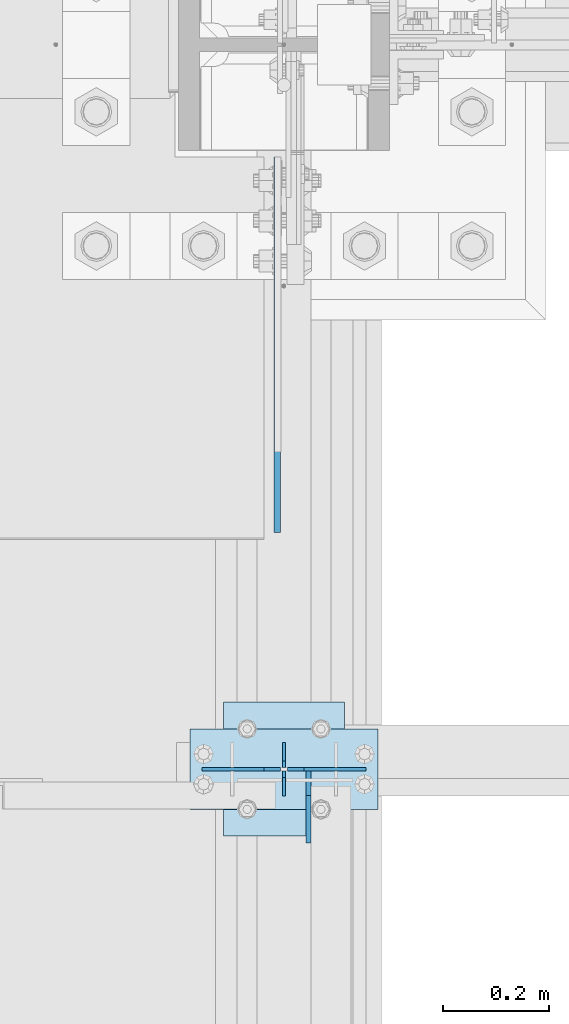
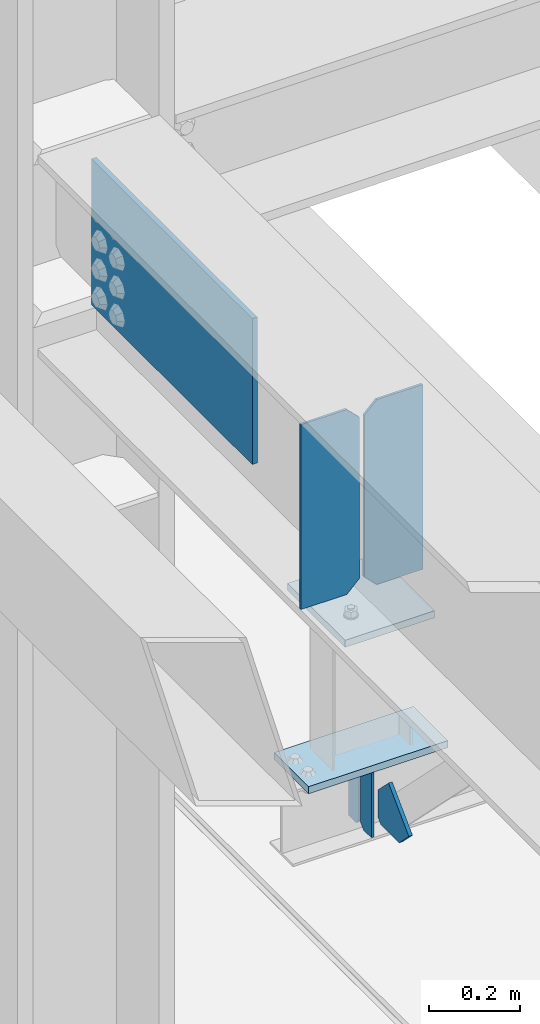
# One storey, part 3337 of 3843: 8 plates, 3 elements without a shape of their own.
"""IFC2X3 building model written with IfcOpenShell, lengths in millimetres."""

import ifcopenshell
import ifcopenshell.guid

model = None  # the IFC model being written
_history = None  # IfcOwnerHistory: only IFC2X3 demands one
_inside = {}  # id of a spatial element -> (the spatial element, [elements in it])
_under = {}  # id of a project, library or spatial element -> (it, [spatial elements below it])
_declared = {}  # id of a project -> (the project, [libraries it declares])
_typed = {}  # id of a type object -> (the type object, [elements of that type])
_made_of = {}  # id of a material, layer set ... -> (it, [elements and type objects made of it])


def new_model(schema):
    """Start an empty IFC model of exactly this schema.

    Asked for "IFC4X3", IfcOpenShell would pick the latest addendum, in which some entities
    have other attributes; the version numbers below select the first issue.
    IFC2X3 requires an IfcOwnerHistory on every rooted entity: one is made here for all.
    """
    global model, _history
    if schema == "IFC4X3":
        model = ifcopenshell.file(schema_version=(4, 3, 0, 0))
    else:
        model = ifcopenshell.file(schema=schema)
    _inside.clear()
    _under.clear()
    _declared.clear()
    _typed.clear()
    _made_of.clear()
    _history = None
    if model.schema == "IFC2X3":
        org = make("IfcOrganization", Name="unknown")
        user = make(
            "IfcPersonAndOrganization",
            ThePerson=make("IfcPerson", FamilyName="unknown"),
            TheOrganization=org,
        )
        app = make(
            "IfcApplication",
            ApplicationDeveloper=org,
            Version="unknown",
            ApplicationFullName="unknown",
            ApplicationIdentifier="unknown",
        )
        _history = make(
            "IfcOwnerHistory",
            OwningUser=user,
            OwningApplication=app,
            ChangeAction="ADDED",
            CreationDate=0,
        )
    return model


def make(cls, **values):
    """One entity of the class cls with the attributes given. An attribute that is None is left unset."""
    return model.create_entity(
        cls, **{name: value for name, value in values.items() if value is not None}
    )


def rooted(cls, **values):
    """An entity with a GlobalId (a new one), such as an element, a storey or a relation."""
    return make(cls, GlobalId=ifcopenshell.guid.new(), OwnerHistory=_history, **values)


def si_unit(unit_type, name, prefix=None):
    """IfcSIUnit, for example si_unit("LENGTHUNIT", "METRE", prefix="MILLI")."""
    return make("IfcSIUnit", UnitType=unit_type, Prefix=prefix, Name=name)


def assignment(units):
    """IfcUnitAssignment: the units of a project."""
    return None if units is None else make("IfcUnitAssignment", Units=units)


def point(xyz):
    """IfcCartesianPoint."""
    return None if xyz is None else make("IfcCartesianPoint", Coordinates=xyz)


def direction(xyz):
    """IfcDirection."""
    return None if xyz is None else make("IfcDirection", DirectionRatios=xyz)


def frame(location, z_axis=None, x_axis=None):
    """IfcAxis2Placement3D, a coordinate frame: its origin and axes. An axis left out is left unset."""
    return make(
        "IfcAxis2Placement3D",
        Location=point(location),
        Axis=direction(z_axis),
        RefDirection=direction(x_axis),
    )


def origin_with_axes():
    """The frame at (0, 0, 0) with the z axis (0, 0, 1) and the x axis (1, 0, 0) written out."""
    return frame((0.0, 0.0, 0.0), z_axis=(0.0, 0.0, 1.0), x_axis=(1.0, 0.0, 0.0))


def place(relative_to, where):
    """IfcLocalPlacement: puts the frame where relative to a parent placement (None: the world)."""
    return make(
        "IfcLocalPlacement", PlacementRelTo=relative_to, RelativePlacement=where
    )


def context(
    kind, dimensions, precision=None, world=None, true_north=None, identifier=None
):
    """IfcGeometricRepresentationContext, for example the 3D "Model" context."""
    return make(
        "IfcGeometricRepresentationContext",
        ContextIdentifier=identifier,
        ContextType=kind,
        CoordinateSpaceDimension=dimensions,
        Precision=precision,
        WorldCoordinateSystem=world,
        TrueNorth=true_north,
    )


def subcontext(parent, identifier, kind, view, scale=None):
    """IfcGeometricRepresentationSubContext, for example "Body" below "Model"."""
    return make(
        "IfcGeometricRepresentationSubContext",
        ContextIdentifier=identifier,
        ContextType=kind,
        ParentContext=parent,
        TargetScale=scale,
        TargetView=view,
    )


def project(units=None, contexts=None):
    """IfcProject with its units and contexts."""
    return rooted(
        "IfcProject",
        Name="project",
        RepresentationContexts=contexts,
        UnitsInContext=assignment(units),
    )


def spatial(cls, under=None, at=None, **own):
    """A site, building, storey or space (cls), placed at a placement, below another one or the project."""
    s = rooted(cls, ObjectPlacement=at, **own)
    if under is not None:
        _under.setdefault(under.id(), (under, []))[1].append(s)
    return s


def faces_of(points, faces, orient=None, outer=None):
    """IfcFace entities. A face is a list of loops; a loop is a list of indices into points, from 0.

    orient and outer hold one flag for each loop. By default every Orientation is true, the
    first loop of a face is its IfcFaceOuterBound and the others are IfcFaceBound.
    """
    made = []
    for i, loops in enumerate(faces):
        bounds = []
        for j, loop in enumerate(loops):
            is_outer = j == 0 if outer is None else outer[i][j]
            bounds.append(
                make(
                    "IfcFaceOuterBound" if is_outer else "IfcFaceBound",
                    Bound=make("IfcPolyLoop", Polygon=[points[k] for k in loop]),
                    Orientation=True if orient is None else orient[i][j],
                )
            )
        made.append(make("IfcFace", Bounds=bounds))
    return made


def faceted_brep(points, faces, orient=None, outer=None, voids=None):
    """IfcFacetedBrep: a solid bounded by flat faces; with voids (closed shells), ...WithVoids."""
    shared = [point(p) for p in points]
    hull = make("IfcClosedShell", CfsFaces=faces_of(shared, faces, orient, outer))
    if voids is None:
        return make("IfcFacetedBrep", Outer=hull)
    return make(
        "IfcFacetedBrepWithVoids",
        Outer=hull,
        Voids=[
            make(cls, CfsFaces=faces_of(shared, fs, o, b)) for cls, fs, o, b in voids
        ],
    )


def shape(context_of_items, identifier, shape_type, items):
    """IfcShapeRepresentation: the items that make up one representation, for example the "Body"."""
    return make(
        "IfcShapeRepresentation",
        ContextOfItems=context_of_items,
        RepresentationIdentifier=identifier,
        RepresentationType=shape_type,
        Items=items,
    )


def material(Name=None, Category=None):
    """IfcMaterial."""
    return make("IfcMaterial", Name=Name, Category=Category)


def made_of(thing, what):
    """Note that an element or type object is made of a material, layer set ...; save() writes the relation."""
    if what is not None:
        _made_of.setdefault(what.id(), (what, []))[1].append(thing)
    return thing


def type_object(cls, material=None, **own):
    """A type object (cls), such as IfcWallType, which elements share."""
    return made_of(rooted(cls, **own), material)


def element(
    cls,
    number,
    at=None,
    inside=None,
    cuts=None,
    type_object=None,
    material=None,
    context=None,
    identifier="Body",
    shape_type=None,
    held_by="IfcProductDefinitionShape",
    body=None,
    shapes=None,
    **own,
):
    """One element of the class cls, such as IfcWall. Its Tag is "e" and its number.

    at: its placement. inside: the storey or other place that contains it. cuts: it is an
    opening in that element (IfcRelVoidsElement). A single representation is given by context,
    identifier, shape_type and body (its items); several are given by shapes. held_by: the class
    of the entity that holds the representations. save() writes the other relations.
    """
    e = rooted(cls, Tag="e%d" % number, ObjectPlacement=at, **own)
    if body is not None:
        shapes = [shape(context, identifier, shape_type, body)]
    if shapes is not None:
        e.Representation = make(held_by, Representations=shapes)
    if inside is not None:
        _inside.setdefault(inside.id(), (inside, []))[1].append(e)
    if cuts is not None:
        rooted(
            "IfcRelVoidsElement", RelatingBuildingElement=cuts, RelatedOpeningElement=e
        )
    if type_object is not None:
        _typed.setdefault(type_object.id(), (type_object, []))[1].append(e)
    return made_of(e, material)


def aggregate(whole, parts):
    """IfcRelAggregates: a whole, such as a stair, and the parts it consists of."""
    return rooted("IfcRelAggregates", RelatingObject=whole, RelatedObjects=parts)


def save(model, path):
    """Write the relations noted so far, then the file.

    IfcRelAggregates (storeys below a building ...), IfcRelContainedInSpatialStructure (elements
    in a storey), IfcRelDefinesByType, IfcRelAssociatesMaterial and IfcRelDeclares: one each for
    every whole, place, type object, material and project.
    """
    for whole, parts in _under.values():
        aggregate(whole, parts)
    for where, things in _inside.values():
        rooted(
            "IfcRelContainedInSpatialStructure",
            RelatedElements=things,
            RelatingStructure=where,
        )
    for kind, things in _typed.values():
        rooted("IfcRelDefinesByType", RelatedObjects=things, RelatingType=kind)
    for what, things in _made_of.values():
        rooted("IfcRelAssociatesMaterial", RelatedObjects=things, RelatingMaterial=what)
    for by, libraries in _declared.values():
        rooted("IfcRelDeclares", RelatingContext=by, RelatedDefinitions=libraries)
    model.write(path)


model = new_model("IFC2X3")

# Units and contexts
model_context = context("Model", 3, precision=1e-05, world=origin_with_axes())
body_context = subcontext(model_context, "Body", "Model", "MODEL_VIEW")
ifc_project = project(units=[si_unit("LENGTHUNIT", "METRE", prefix="MILLI"), si_unit("AREAUNIT", "SQUARE_METRE"), si_unit("VOLUMEUNIT", "CUBIC_METRE"), si_unit("MASSUNIT", "GRAM", prefix="KILO"), si_unit("TIMEUNIT", "SECOND"), si_unit("PLANEANGLEUNIT", "RADIAN"), si_unit("SOLIDANGLEUNIT", "STERADIAN"), si_unit("THERMODYNAMICTEMPERATUREUNIT", "DEGREE_CELSIUS"), si_unit("LUMINOUSINTENSITYUNIT", "LUMEN")], contexts=[model_context])

# Site, building, storey
site_placement = place(None, origin_with_axes())
site = spatial("IfcSite", under=ifc_project, at=site_placement, CompositionType="ELEMENT")
building_placement = place(site_placement, origin_with_axes())
building = spatial("IfcBuilding", under=site, at=building_placement, Name="Undefined", CompositionType="ELEMENT")
storey_placement = place(building_placement, origin_with_axes())
storey = spatial("IfcBuildingStorey", under=building, at=storey_placement, Name="Undefined", CompositionType="ELEMENT", Elevation=0.0)

# Assembly, plates
assembly_1_placement = place(storey_placement, origin_with_axes())
assembly_1 = element("IfcElementAssembly", 1, at=assembly_1_placement, inside=storey, Name="BEAM", AssemblyPlace="NOTDEFINED", PredefinedType="RIGID_FRAME")
ifc_material = material(Name="STEEL/A572-50")
plate_type_1 = type_object("IfcPlateType", PredefinedType="NOTDEFINED")
plate_1_placement = place(assembly_1_placement, frame((36576.0000030517, 65951.1, 41495.6625), z_axis=(0.0, 0.0, -1.0), x_axis=(0.0, -1.0, 0.0)))
plate_1 = element("IfcPlate", 2, at=plate_1_placement, type_object=plate_type_1, material=ifc_material, Name="PLATE", context=body_context, shape_type="Brep", body=[
    faceted_brep([(0.0, -3.17499999999927, 0.0), (0.0, -3.17500000000291, 187.324999999997), (0.0, 3.17500000000291, 187.324999999997), (0.0, 3.17499999999927, 0.0), (34.9250001907349, -3.17500000000291, 187.324999999997), (34.9250001907349, 3.17500000000291, 187.324999999997), (47.625, -3.17500000000291, 174.625000190732), (47.625, 3.17500000000291, 174.625000190732), (47.625, -3.17499999999927, 12.6999998092651), (47.625, 3.17499999999927, 12.6999998092651), (34.9250001907349, -3.17499999999927, 0.0), (34.9250001907349, 3.17499999999927, 0.0)], [[[0, 1, 2, 3]], [[1, 4, 5, 2]], [[4, 6, 7, 5]], [[6, 8, 9, 7]], [[8, 10, 11, 9]], [[10, 0, 3, 11]], [[5, 7, 9, 11, 3, 2]], [[10, 8, 6, 4, 1, 0]]]),
])
plate_2_placement = place(assembly_1_placement, frame((36576.0000030517, 65849.5, 41495.6625), z_axis=(0.0, 0.0, -1.0), x_axis=(0.0, 1.0, 0.0)))
plate_2 = element("IfcPlate", 3, at=plate_2_placement, type_object=plate_type_1, material=ifc_material, Name="PLATE", context=body_context, shape_type="Brep", body=[
    faceted_brep([(0.0, -3.17499999999927, 0.0), (0.0, -3.17500000000291, 187.324999999997), (0.0, 3.17500000000291, 187.324999999997), (0.0, 3.17499999999927, 0.0), (34.9250001907349, -3.17500000000291, 187.324999999997), (34.9250001907349, 3.17500000000291, 187.324999999997), (47.625, -3.17500000000291, 174.625000190732), (47.625, 3.17500000000291, 174.625000190732), (47.625, -3.17499999999927, 12.6999998092651), (47.625, 3.17499999999927, 12.6999998092651), (34.9250001907349, -3.17499999999927, 0.0), (34.9250001907349, 3.17499999999927, 0.0)], [[[0, 1, 2, 3]], [[1, 4, 5, 2]], [[4, 6, 7, 5]], [[6, 8, 9, 7]], [[8, 10, 11, 9]], [[10, 0, 3, 11]], [[5, 7, 9, 11, 3, 2]], [[10, 8, 6, 4, 1, 0]]]),
])

# Assembly, plate
assembly_2_placement = place(storey_placement, origin_with_axes())
assembly_2 = element("IfcElementAssembly", 4, at=assembly_2_placement, inside=storey, Name="POST", AssemblyPlace="NOTDEFINED", PredefinedType="RIGID_FRAME")
plate_type_2 = type_object("IfcPlateType", PredefinedType="NOTDEFINED")
plate_3_placement = place(assembly_2_placement, frame((36753.8000030518, 65824.1, 41513.125), z_axis=(-1.0, 0.0, 0.0), x_axis=(0.0, 1.0, 0.0)))
plate_3 = element("IfcPlate", 5, at=plate_3_placement, type_object=plate_type_2, material=ifc_material, Name="PLATE", context=body_context, shape_type="Brep", body=[
    faceted_brep([(0.0, -9.52500000000146, 0.0), (0.0, -9.52500000000146, 355.599999999999), (0.0, 9.52500000000146, 355.599999999999), (0.0, 9.52500000000146, 0.0), (152.399999999994, -9.52500000000146, 355.599999999999), (152.399999999994, 9.52500000000146, 355.599999999999), (152.400000000001, -9.52500000000146, 0.0), (152.400000000001, 9.52500000000146, 0.0)], [[[0, 1, 2, 3]], [[1, 4, 5, 2]], [[4, 6, 7, 5]], [[6, 0, 3, 7]], [[5, 7, 3, 2]], [[6, 4, 1, 0]]]),
])

# Assembly, plates
assembly_3_placement = place(storey_placement, origin_with_axes())
assembly_3 = element("IfcElementAssembly", 6, at=assembly_3_placement, inside=storey, Name="BEAM", AssemblyPlace="NOTDEFINED", PredefinedType="RIGID_FRAME")
plate_type_3 = type_object("IfcPlateType", PredefinedType="NOTDEFINED")
plate_4_placement = place(assembly_3_placement, frame((36731.575, 65900.3, 42446.575), z_axis=(0.0, 0.0, -1.0), x_axis=(-1.0, 0.0, 0.0)))
plate_4 = element("IfcPlate", 7, at=plate_4_placement, type_object=plate_type_3, material=ifc_material, Name="PLATE", context=body_context, shape_type="Brep", body=[
    faceted_brep([(0.0, -3.17499999999927, 0.0), (0.0, -3.17500000000291, 498.475000000006), (0.0, 3.17500000000291, 498.475000000006), (0.0, 3.17499999999927, 0.0), (117.475000000006, -3.17500000000291, 498.475000000006), (117.475000000006, 3.17500000000291, 498.475000000006), (149.225000000006, -3.17500000000291, 466.725000000006), (149.225000000006, 3.17500000000291, 466.725000000006), (149.225000000006, -3.17500000000291, 31.75), (149.225000000006, 3.17500000000291, 31.75), (117.475000000006, -3.17500000000291, 0.0), (117.475000000006, 3.17500000000291, 0.0)], [[[0, 1, 2, 3]], [[1, 4, 5, 2]], [[4, 6, 7, 5]], [[6, 8, 9, 7]], [[8, 10, 11, 9]], [[10, 0, 3, 11]], [[5, 7, 9, 11, 3, 2]], [[10, 8, 6, 4, 1, 0]]]),
])
plate_5_placement = place(assembly_3_placement, frame((36420.425, 65900.3, 42446.575), z_axis=(0.0, 0.0, -1.0), x_axis=(1.0, 0.0, 0.0)))
plate_5 = element("IfcPlate", 8, at=plate_5_placement, type_object=plate_type_3, material=ifc_material, Name="PLATE", context=body_context, shape_type="Brep", body=[
    faceted_brep([(0.0, -3.17499999999927, 0.0), (0.0, -3.17500000000291, 498.475000000006), (0.0, 3.17500000000291, 498.475000000006), (0.0, 3.17499999999927, 0.0), (117.475000000006, -3.17500000000291, 498.475000000006), (117.475000000006, 3.17500000000291, 498.475000000006), (149.225000000006, -3.17500000000291, 466.725000000006), (149.225000000006, 3.17500000000291, 466.725000000006), (149.225000000006, -3.17500000000291, 31.75), (149.225000000006, 3.17500000000291, 31.75), (117.475000000006, -3.17500000000291, 0.0), (117.475000000006, 3.17500000000291, 0.0)], [[[0, 1, 2, 3]], [[1, 4, 5, 2]], [[4, 6, 7, 5]], [[6, 8, 9, 7]], [[8, 10, 11, 9]], [[10, 0, 3, 11]], [[5, 7, 9, 11, 3, 2]], [[10, 8, 6, 4, 1, 0]]]),
])

# Plate
plate_type_4 = type_object("IfcPlateType", PredefinedType="NOTDEFINED")
plate_6_placement = place(assembly_2_placement, frame((36461.7000005181, 66027.3, 41916.35), z_axis=(0.0, -1.0, 0.0), x_axis=(1.0, 0.0, 0.0)))
plate_6 = element("IfcPlate", 9, at=plate_6_placement, type_object=plate_type_4, material=ifc_material, Name="PLATE", context=body_context, shape_type="Brep", body=[
    faceted_brep([(0.0, -9.52500000000146, 0.0), (0.0, -9.52500000000146, 254.0), (0.0, 9.52500000000146, 254.0), (0.0, 9.52500000000146, 0.0), (228.599999999999, -9.52500000000146, 254.0), (228.599999999999, 9.52500000000146, 254.0), (228.599999999999, -9.52500000000146, 0.0), (228.599999999999, 9.52500000000146, 0.0)], [[[0, 1, 2, 3]], [[1, 4, 5, 2]], [[4, 6, 7, 5]], [[6, 0, 3, 7]], [[5, 7, 3, 2]], [[6, 4, 1, 0]]]),
])

aggregate(assembly_2, [plate_6, plate_3])

plate_type_5 = type_object("IfcPlateType", PredefinedType="NOTDEFINED")
plate_7_placement = place(assembly_1_placement, frame((36622.0375, 65897.125, 41306.75), z_axis=(0.0, -1.0, 0.0), x_axis=(0.0, 0.0, 1.0)))
plate_7 = element("IfcPlate", 10, at=plate_7_placement, type_object=plate_type_5, material=ifc_material, Name="PLATE", context=body_context, shape_type="Brep", body=[
    faceted_brep([(0.0, -4.76250000000073, 12.6999998092651), (4.450703272596e-08, -4.76249999999709, 93.0710244828806), (4.450703272596e-08, 4.76249999999709, 93.0710244828806), (0.0, 4.76250000000073, 12.6999998092651), (43.3137807601452, -4.76249999999709, 136.384805065652), (43.3137807601452, 4.76249999999709, 136.384805065652), (133.209805202001, -4.76249999999709, 46.4887805392646), (133.209805202001, 4.76249999999709, 46.4887805392646), (86.7210245267561, -4.76249999999709, 0.0), (86.7210245267561, 4.76249999999709, 0.0), (12.6999998092651, -4.76250000000073, 0.0), (12.6999998092651, 4.76250000000073, 0.0)], [[[0, 1, 2, 3]], [[1, 4, 5, 2]], [[4, 6, 7, 5]], [[6, 8, 9, 7]], [[8, 10, 11, 9]], [[10, 0, 3, 11]], [[5, 7, 9, 11, 3, 2]], [[10, 8, 6, 4, 1, 0]]]),
])

aggregate(assembly_1, [plate_1, plate_2, plate_7])

plate_type_6 = type_object("IfcPlateType", PredefinedType="NOTDEFINED")
plate_8_placement = place(assembly_3_placement, frame((36563.3, 66347.975, 42017.95), z_axis=(0.0, 0.0, 1.0), x_axis=(0.0, 1.0, 0.0)))
plate_8 = element("IfcPlate", 11, at=plate_8_placement, type_object=plate_type_6, material=ifc_material, Name="PLATE", context=body_context, shape_type="Brep", body=[
    faceted_brep([(0.0, -6.3499999046162, 0.0), (0.0, -6.34999999999854, 393.700012207031), (0.0, 6.34999999999854, 393.700012207031), (7.27595761418343e-12, 6.3499999046162, 0.0), (711.199999999968, -6.35000000000582, 393.700012207031), (711.200000000012, 6.34999999999854, 393.700000000004), (711.199999999968, -6.35000000000582, 0.0), (711.199999999997, 6.34999999999854, 0.0)], [[[0, 1, 2, 3]], [[1, 4, 5, 2]], [[4, 6, 7, 5]], [[6, 0, 3, 7]], [[7, 3, 2, 5]], [[6, 4, 1, 0]]]),
])

aggregate(assembly_3, [plate_4, plate_5, plate_8])

save(model, "model.ifc")
